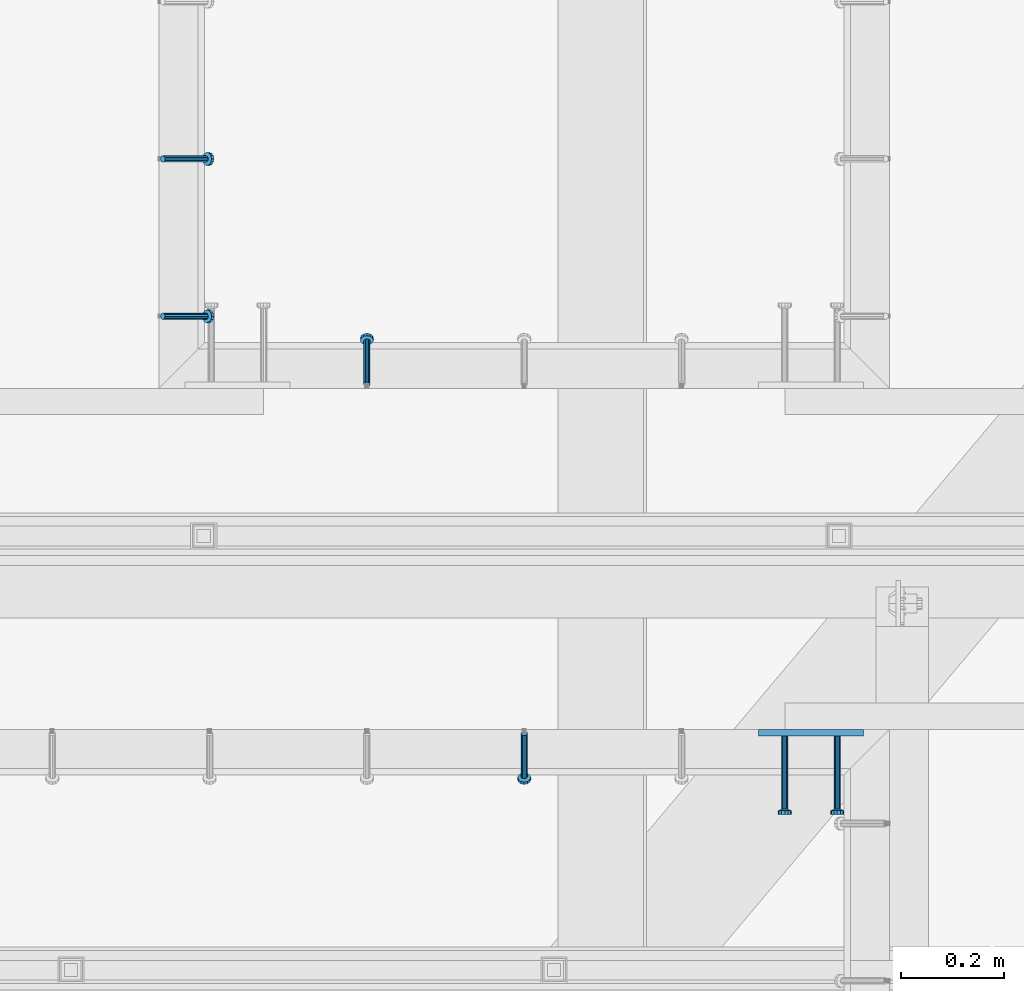
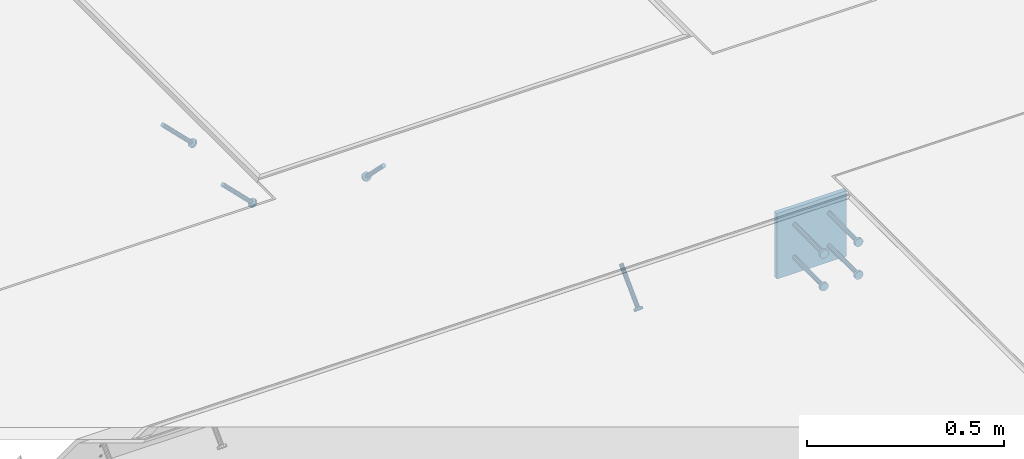
# One storey, part 2120 of 3843: 5 beams, 4 members, 4 elements without a shape of their own.
"""IFC2X3 building model written with IfcOpenShell, lengths in millimetres."""

from ifc_helpers import new_model, si_unit, frame, origin_with_axes, place, context, subcontext, project, spatial, faceted_brep, material, type_object, element, aggregate, save


model = new_model("IFC2X3")

# Units and contexts
model_context = context("Model", 3, precision=1e-05, world=origin_with_axes())
body_context = subcontext(model_context, "Body", "Model", "MODEL_VIEW")
ifc_project = project(units=[si_unit("LENGTHUNIT", "METRE", prefix="MILLI"), si_unit("AREAUNIT", "SQUARE_METRE"), si_unit("VOLUMEUNIT", "CUBIC_METRE"), si_unit("MASSUNIT", "GRAM", prefix="KILO"), si_unit("TIMEUNIT", "SECOND"), si_unit("PLANEANGLEUNIT", "RADIAN"), si_unit("SOLIDANGLEUNIT", "STERADIAN"), si_unit("THERMODYNAMICTEMPERATUREUNIT", "DEGREE_CELSIUS"), si_unit("LUMINOUSINTENSITYUNIT", "LUMEN")], contexts=[model_context])

# Site, building, storey
site_placement = place(None, origin_with_axes())
site = spatial("IfcSite", under=ifc_project, at=site_placement, CompositionType="ELEMENT")
building_placement = place(site_placement, origin_with_axes())
building = spatial("IfcBuilding", under=site, at=building_placement, Name="Undefined", CompositionType="ELEMENT")
storey_placement = place(building_placement, origin_with_axes())
storey = spatial("IfcBuildingStorey", under=building, at=storey_placement, Name="Undefined", CompositionType="ELEMENT", Elevation=0.0)

# Assembly, member
assembly_1_placement = place(storey_placement, origin_with_axes())
assembly_1 = element("IfcElementAssembly", 1, at=assembly_1_placement, inside=storey, Name="EMBED_ANGLE", AssemblyPlace="NOTDEFINED", PredefinedType="RIGID_FRAME")
ifc_material_1 = material(Name="STEEL/A108")
member_type = type_object("IfcMemberType", PredefinedType="NOTDEFINED")
member_1_placement = place(assembly_1_placement, frame((50270.5370209961, 28836.9375, 30446.6625), z_axis=(-1.0, 0.0, 0.0), x_axis=(5.70000238222118e-08, 0.707106781186546, -0.707106781186546)))
member_1 = element("IfcMember", 2, at=member_1_placement, type_object=member_type, material=ifc_material_1, Name="HEADED STUD ANCHOR", context=body_context, shape_type="Brep", body=[
    faceted_brep([(7.27595761418343e-12, -3.18000006675175, 5.5), (0.0, -5.49999999998363, 3.1800000667572), (118.110000000976, -5.49999999999091, 3.1800000667572), (118.110000000983, -3.18000006675175, 5.5), (0.0, -6.3499999046162, 0.0), (118.110000000968, -6.34999990461256, 0.0), (0.0, -5.49999999998363, -3.1800000667572), (118.110000000976, -5.49999999999091, -3.1800000667572), (7.27595761418343e-12, -3.18000006675175, -5.5), (118.110000000983, -3.18000006675175, -5.5), (7.27595761418343e-12, -1.81898940354586e-12, -6.34999990463257), (118.110000000968, -1.81898940354586e-12, -6.34999990463257), (0.0, 3.18000006675175, -5.5), (118.110000000968, 3.18000006674811, -5.5), (7.27595761418343e-12, 5.49999999998363, -3.1800000667572), (118.110000000983, 5.49999999998363, -3.1800000667572), (7.27595761418343e-12, 6.3499999046162, 0.0), (118.110000000976, 6.34999990461256, 0.0), (7.27595761418343e-12, 5.49999999998363, 3.1800000667572), (118.110000000983, 5.49999999998363, 3.1800000667572), (0.0, 3.18000006675175, 5.5), (118.110000000968, 3.18000006674811, 5.5), (7.27595761418343e-12, -1.81898940354586e-12, 6.34999990463257), (118.110000000968, -1.81898940354586e-12, 6.34999990463257), (120.650000000991, -10.9899997710909, 6.34999990463257), (120.650000000998, -6.34000015257152, 10.9899997711182), (120.650000000991, -12.6999998092379, 0.0), (120.650000000991, -10.9899997710909, -6.34999990463257), (120.650000000998, -6.34000015257152, -10.9899997711182), (120.650000000991, -1.81898940354586e-12, -12.6899995803833), (120.650000000991, 6.34000015257152, -10.9899997711182), (120.650000000998, 10.9899997710909, -6.34999990463257), (120.650000000991, 12.6999998092342, 0.0), (120.650000000998, 10.9899997710909, 6.34999990463257), (120.650000000991, 6.34000015257152, 10.9899997711182), (120.650000000991, -1.81898940354586e-12, 12.6899995803833), (127.000000001048, -10.9899997710945, 6.34999990463257), (127.000000001048, -6.34000015257152, 10.9899997711182), (127.000000001048, -12.6999998092342, 0.0), (127.000000001048, -10.9899997710945, -6.34999990463257), (127.000000001048, -6.34000015257152, -10.9899997711182), (127.000000001048, 1.81898940354586e-12, -12.6899995803833), (127.000000001048, 6.34000015256788, -10.9899997711182), (127.000000001048, 10.9899997710909, -6.34999990463257), (127.000000001048, 12.6999998092379, 0.0), (127.000000001048, 10.9899997710909, 6.34999990463257), (127.000000001048, 6.34000015256788, 10.9899997711182), (127.000000001048, 1.81898940354586e-12, 12.6899995803833)], [[[0, 1, 2, 3]], [[1, 4, 5, 2]], [[4, 6, 7, 5]], [[6, 8, 9, 7]], [[8, 10, 11, 9]], [[10, 12, 13, 11]], [[12, 14, 15, 13]], [[14, 16, 17, 15]], [[16, 18, 19, 17]], [[18, 20, 21, 19]], [[20, 22, 23, 21]], [[22, 0, 3, 23]], [[22, 20, 18, 16, 14, 12, 10, 8, 6, 4, 1, 0]], [[3, 2, 24, 25]], [[2, 5, 26, 24]], [[5, 7, 27, 26]], [[7, 9, 28, 27]], [[9, 11, 29, 28]], [[11, 13, 30, 29]], [[13, 15, 31, 30]], [[15, 17, 32, 31]], [[17, 19, 33, 32]], [[19, 21, 34, 33]], [[21, 23, 35, 34]], [[23, 3, 25, 35]], [[25, 24, 36, 37]], [[24, 26, 38, 36]], [[26, 27, 39, 38]], [[27, 28, 40, 39]], [[28, 29, 41, 40]], [[29, 30, 42, 41]], [[30, 31, 43, 42]], [[31, 32, 44, 43]], [[32, 33, 45, 44]], [[33, 34, 46, 45]], [[34, 35, 47, 46]], [[35, 25, 37, 47]], [[38, 39, 40, 41, 42, 43, 44, 45, 46, 47, 37, 36]]]),
])
aggregate(assembly_1, [member_1])

assembly_2_placement = place(storey_placement, origin_with_axes())
assembly_2 = element("IfcElementAssembly", 3, at=assembly_2_placement, inside=storey, Name="EMBED_ANGLE", AssemblyPlace="NOTDEFINED", PredefinedType="RIGID_FRAME")
member_2_placement = place(assembly_2_placement, frame((50575.337, 28160.6625, 30446.6625), z_axis=(-1.0, 0.0, 0.0), x_axis=(0.0, -0.707106781186548, -0.707106781186548)))
member_2 = element("IfcMember", 4, at=member_2_placement, type_object=member_type, material=ifc_material_1, Name="HEADED STUD ANCHOR", context=body_context, shape_type="Brep", body=[
    faceted_brep([(7.27595761418343e-12, -3.18000006675175, 5.5), (0.0, -5.49999999998363, 3.1800000667572), (118.110000000976, -5.49999999999091, 3.1800000667572), (118.110000000983, -3.18000006675175, 5.5), (0.0, -6.3499999046162, 0.0), (118.110000000968, -6.34999990461256, 0.0), (0.0, -5.49999999998363, -3.1800000667572), (118.110000000976, -5.49999999999091, -3.1800000667572), (7.27595761418343e-12, -3.18000006675175, -5.5), (118.110000000983, -3.18000006675175, -5.5), (7.27595761418343e-12, -1.81898940354586e-12, -6.34999990463257), (118.110000000968, -1.81898940354586e-12, -6.34999990463257), (0.0, 3.18000006675175, -5.5), (118.110000000968, 3.18000006674811, -5.5), (7.27595761418343e-12, 5.49999999998363, -3.1800000667572), (118.110000000983, 5.49999999998363, -3.1800000667572), (7.27595761418343e-12, 6.3499999046162, 0.0), (118.110000000976, 6.34999990461256, 0.0), (7.27595761418343e-12, 5.49999999998363, 3.1800000667572), (118.110000000983, 5.49999999998363, 3.1800000667572), (0.0, 3.18000006675175, 5.5), (118.110000000968, 3.18000006674811, 5.5), (7.27595761418343e-12, -1.81898940354586e-12, 6.34999990463257), (118.110000000968, -1.81898940354586e-12, 6.34999990463257), (120.650000000991, -10.9899997710909, 6.34999990463257), (120.650000000998, -6.34000015257152, 10.9899997711182), (120.650000000991, -12.6999998092379, 0.0), (120.650000000991, -10.9899997710909, -6.34999990463257), (120.650000000998, -6.34000015257152, -10.9899997711182), (120.650000000991, -1.81898940354586e-12, -12.6899995803833), (120.650000000991, 6.34000015257152, -10.9899997711182), (120.650000000998, 10.9899997710909, -6.34999990463257), (120.650000000991, 12.6999998092342, 0.0), (120.650000000998, 10.9899997710909, 6.34999990463257), (120.650000000991, 6.34000015257152, 10.9899997711182), (120.650000000991, -1.81898940354586e-12, 12.6899995803833), (127.000000001048, -10.9899997710945, 6.34999990463257), (127.000000001048, -6.34000015257152, 10.9899997711182), (127.000000001048, -12.6999998092342, 0.0), (127.000000001048, -10.9899997710945, -6.34999990463257), (127.000000001048, -6.34000015257152, -10.9899997711182), (127.000000001048, 1.81898940354586e-12, -12.6899995803833), (127.000000001048, 6.34000015256788, -10.9899997711182), (127.000000001048, 10.9899997710909, -6.34999990463257), (127.000000001048, 12.6999998092379, 0.0), (127.000000001048, 10.9899997710909, 6.34999990463257), (127.000000001048, 6.34000015256788, 10.9899997711182), (127.000000001048, 1.81898940354586e-12, 12.6899995803833)], [[[0, 1, 2, 3]], [[1, 4, 5, 2]], [[4, 6, 7, 5]], [[6, 8, 9, 7]], [[8, 10, 11, 9]], [[10, 12, 13, 11]], [[12, 14, 15, 13]], [[14, 16, 17, 15]], [[16, 18, 19, 17]], [[18, 20, 21, 19]], [[20, 22, 23, 21]], [[22, 0, 3, 23]], [[22, 20, 18, 16, 14, 12, 10, 8, 6, 4, 1, 0]], [[3, 2, 24, 25]], [[2, 5, 26, 24]], [[5, 7, 27, 26]], [[7, 9, 28, 27]], [[9, 11, 29, 28]], [[11, 13, 30, 29]], [[13, 15, 31, 30]], [[15, 17, 32, 31]], [[17, 19, 33, 32]], [[19, 21, 34, 33]], [[21, 23, 35, 34]], [[23, 3, 25, 35]], [[25, 24, 36, 37]], [[24, 26, 38, 36]], [[26, 27, 39, 38]], [[27, 28, 40, 39]], [[28, 29, 41, 40]], [[29, 30, 42, 41]], [[30, 31, 43, 42]], [[31, 32, 44, 43]], [[32, 33, 45, 44]], [[33, 34, 46, 45]], [[34, 35, 47, 46]], [[35, 25, 37, 47]], [[38, 39, 40, 41, 42, 43, 44, 45, 46, 47, 37, 36]]]),
])
aggregate(assembly_2, [member_2])

# Assembly, members
assembly_3_placement = place(storey_placement, origin_with_axes())
assembly_3 = element("IfcElementAssembly", 5, at=assembly_3_placement, inside=storey, Name="EMBED_ANGLE", AssemblyPlace="NOTDEFINED", PredefinedType="RIGID_FRAME")
member_3_placement = place(assembly_3_placement, frame((49875.2495576171, 28968.826609375, 30446.6625), z_axis=(0.0, 1.0, 0.0), x_axis=(0.707106781186548, 0.0, -0.707106781186548)))
member_3 = element("IfcMember", 6, at=member_3_placement, type_object=member_type, material=ifc_material_1, Name="HEADED STUD ANCHOR", context=body_context, shape_type="Brep", body=[
    faceted_brep([(7.27595761418343e-12, -3.18000006675175, 5.5), (0.0, -5.49999999998363, 3.1800000667572), (118.110000000976, -5.49999999999091, 3.1800000667572), (118.110000000983, -3.18000006675175, 5.5), (0.0, -6.3499999046162, 0.0), (118.110000000968, -6.34999990461256, 0.0), (0.0, -5.49999999998363, -3.1800000667572), (118.110000000976, -5.49999999999091, -3.1800000667572), (7.27595761418343e-12, -3.18000006675175, -5.5), (118.110000000983, -3.18000006675175, -5.5), (7.27595761418343e-12, -1.81898940354586e-12, -6.34999990463257), (118.110000000968, -1.81898940354586e-12, -6.34999990463257), (0.0, 3.18000006675175, -5.5), (118.110000000968, 3.18000006674811, -5.5), (7.27595761418343e-12, 5.49999999998363, -3.1800000667572), (118.110000000983, 5.49999999998363, -3.1800000667572), (7.27595761418343e-12, 6.3499999046162, 0.0), (118.110000000976, 6.34999990461256, 0.0), (7.27595761418343e-12, 5.49999999998363, 3.1800000667572), (118.110000000983, 5.49999999998363, 3.1800000667572), (0.0, 3.18000006675175, 5.5), (118.110000000968, 3.18000006674811, 5.5), (7.27595761418343e-12, -1.81898940354586e-12, 6.34999990463257), (118.110000000968, -1.81898940354586e-12, 6.34999990463257), (120.650000000991, -10.9899997710909, 6.34999990463257), (120.650000000998, -6.34000015257152, 10.9899997711182), (120.650000000991, -12.6999998092379, 0.0), (120.650000000991, -10.9899997710909, -6.34999990463257), (120.650000000998, -6.34000015257152, -10.9899997711182), (120.650000000991, -1.81898940354586e-12, -12.6899995803833), (120.650000000991, 6.34000015257152, -10.9899997711182), (120.650000000998, 10.9899997710909, -6.34999990463257), (120.650000000991, 12.6999998092342, 0.0), (120.650000000998, 10.9899997710909, 6.34999990463257), (120.650000000991, 6.34000015257152, 10.9899997711182), (120.650000000991, -1.81898940354586e-12, 12.6899995803833), (127.000000001048, -10.9899997710945, 6.34999990463257), (127.000000001048, -6.34000015257152, 10.9899997711182), (127.000000001048, -12.6999998092342, 0.0), (127.000000001048, -10.9899997710945, -6.34999990463257), (127.000000001048, -6.34000015257152, -10.9899997711182), (127.000000001048, 1.81898940354586e-12, -12.6899995803833), (127.000000001048, 6.34000015256788, -10.9899997711182), (127.000000001048, 10.9899997710909, -6.34999990463257), (127.000000001048, 12.6999998092379, 0.0), (127.000000001048, 10.9899997710909, 6.34999990463257), (127.000000001048, 6.34000015256788, 10.9899997711182), (127.000000001048, 1.81898940354586e-12, 12.6899995803833)], [[[0, 1, 2, 3]], [[1, 4, 5, 2]], [[4, 6, 7, 5]], [[6, 8, 9, 7]], [[8, 10, 11, 9]], [[10, 12, 13, 11]], [[12, 14, 15, 13]], [[14, 16, 17, 15]], [[16, 18, 19, 17]], [[18, 20, 21, 19]], [[20, 22, 23, 21]], [[22, 0, 3, 23]], [[22, 20, 18, 16, 14, 12, 10, 8, 6, 4, 1, 0]], [[3, 2, 24, 25]], [[2, 5, 26, 24]], [[5, 7, 27, 26]], [[7, 9, 28, 27]], [[9, 11, 29, 28]], [[11, 13, 30, 29]], [[13, 15, 31, 30]], [[15, 17, 32, 31]], [[17, 19, 33, 32]], [[19, 21, 34, 33]], [[21, 23, 35, 34]], [[23, 3, 25, 35]], [[25, 24, 36, 37]], [[24, 26, 38, 36]], [[26, 27, 39, 38]], [[27, 28, 40, 39]], [[28, 29, 41, 40]], [[29, 30, 42, 41]], [[30, 31, 43, 42]], [[31, 32, 44, 43]], [[32, 33, 45, 44]], [[33, 34, 46, 45]], [[34, 35, 47, 46]], [[35, 25, 37, 47]], [[38, 39, 40, 41, 42, 43, 44, 45, 46, 47, 37, 36]]]),
])
member_4_placement = place(assembly_3_placement, frame((49875.2495576171, 29273.626609375, 30446.6625), z_axis=(0.0, 1.0, 0.0), x_axis=(0.707106781186548, 0.0, -0.707106781186548)))
member_4 = element("IfcMember", 7, at=member_4_placement, type_object=member_type, material=ifc_material_1, Name="HEADED STUD ANCHOR", context=body_context, shape_type="Brep", body=[
    faceted_brep([(7.27595761418343e-12, -3.18000006675175, 5.5), (0.0, -5.49999999998363, 3.1800000667572), (118.110000000976, -5.49999999999091, 3.1800000667572), (118.110000000983, -3.18000006675175, 5.5), (0.0, -6.3499999046162, 0.0), (118.110000000968, -6.34999990461256, 0.0), (0.0, -5.49999999998363, -3.1800000667572), (118.110000000976, -5.49999999999091, -3.1800000667572), (7.27595761418343e-12, -3.18000006675175, -5.5), (118.110000000983, -3.18000006675175, -5.5), (7.27595761418343e-12, -1.81898940354586e-12, -6.34999990463257), (118.110000000968, -1.81898940354586e-12, -6.34999990463257), (0.0, 3.18000006675175, -5.5), (118.110000000968, 3.18000006674811, -5.5), (7.27595761418343e-12, 5.49999999998363, -3.1800000667572), (118.110000000983, 5.49999999998363, -3.1800000667572), (7.27595761418343e-12, 6.3499999046162, 0.0), (118.110000000976, 6.34999990461256, 0.0), (7.27595761418343e-12, 5.49999999998363, 3.1800000667572), (118.110000000983, 5.49999999998363, 3.1800000667572), (0.0, 3.18000006675175, 5.5), (118.110000000968, 3.18000006674811, 5.5), (7.27595761418343e-12, -1.81898940354586e-12, 6.34999990463257), (118.110000000968, -1.81898940354586e-12, 6.34999990463257), (120.650000000991, -10.9899997710909, 6.34999990463257), (120.650000000998, -6.34000015257152, 10.9899997711182), (120.650000000991, -12.6999998092379, 0.0), (120.650000000991, -10.9899997710909, -6.34999990463257), (120.650000000998, -6.34000015257152, -10.9899997711182), (120.650000000991, -1.81898940354586e-12, -12.6899995803833), (120.650000000991, 6.34000015257152, -10.9899997711182), (120.650000000998, 10.9899997710909, -6.34999990463257), (120.650000000991, 12.6999998092342, 0.0), (120.650000000998, 10.9899997710909, 6.34999990463257), (120.650000000991, 6.34000015257152, 10.9899997711182), (120.650000000991, -1.81898940354586e-12, 12.6899995803833), (127.000000001048, -10.9899997710945, 6.34999990463257), (127.000000001048, -6.34000015257152, 10.9899997711182), (127.000000001048, -12.6999998092342, 0.0), (127.000000001048, -10.9899997710945, -6.34999990463257), (127.000000001048, -6.34000015257152, -10.9899997711182), (127.000000001048, 1.81898940354586e-12, -12.6899995803833), (127.000000001048, 6.34000015256788, -10.9899997711182), (127.000000001048, 10.9899997710909, -6.34999990463257), (127.000000001048, 12.6999998092379, 0.0), (127.000000001048, 10.9899997710909, 6.34999990463257), (127.000000001048, 6.34000015256788, 10.9899997711182), (127.000000001048, 1.81898940354586e-12, 12.6899995803833)], [[[0, 1, 2, 3]], [[1, 4, 5, 2]], [[4, 6, 7, 5]], [[6, 8, 9, 7]], [[8, 10, 11, 9]], [[10, 12, 13, 11]], [[12, 14, 15, 13]], [[14, 16, 17, 15]], [[16, 18, 19, 17]], [[18, 20, 21, 19]], [[20, 22, 23, 21]], [[22, 0, 3, 23]], [[22, 20, 18, 16, 14, 12, 10, 8, 6, 4, 1, 0]], [[3, 2, 24, 25]], [[2, 5, 26, 24]], [[5, 7, 27, 26]], [[7, 9, 28, 27]], [[9, 11, 29, 28]], [[11, 13, 30, 29]], [[13, 15, 31, 30]], [[15, 17, 32, 31]], [[17, 19, 33, 32]], [[19, 21, 34, 33]], [[21, 23, 35, 34]], [[23, 3, 25, 35]], [[25, 24, 36, 37]], [[24, 26, 38, 36]], [[26, 27, 39, 38]], [[27, 28, 40, 39]], [[28, 29, 41, 40]], [[29, 30, 42, 41]], [[30, 31, 43, 42]], [[31, 32, 44, 43]], [[32, 33, 45, 44]], [[33, 34, 46, 45]], [[34, 35, 47, 46]], [[35, 25, 37, 47]], [[38, 39, 40, 41, 42, 43, 44, 45, 46, 47, 37, 36]]]),
])
aggregate(assembly_3, [member_3, member_4])

# Assembly, beams
assembly_4_placement = place(storey_placement, origin_with_axes())
assembly_4 = element("IfcElementAssembly", 8, at=assembly_4_placement, inside=storey, Name="EMBED PLATE", AssemblyPlace="NOTDEFINED", PredefinedType="RIGID_FRAME")
ifc_material_2 = material(Name="STEEL/A36")
beam_type_1 = type_object("IfcBeamType", PredefinedType="NOTDEFINED")
beam_1_placement = place(assembly_4_placement, frame((51130.962, 28162.25, 30445.075), z_axis=(-1.0, 0.0, 0.0), x_axis=(0.0, 0.0, -1.0)))
beam_1 = element("IfcBeam", 9, at=beam_1_placement, type_object=beam_type_1, material=ifc_material_2, Name="EMBED PLATE", context=body_context, shape_type="Brep", body=[
    faceted_brep([(1.74622982740402e-10, 6.35000000000582, -101.600000000195), (-1.67347025126219e-10, 6.35000000000582, 101.600000000151), (203.200000000001, 6.35000000000582, 101.599999999999), (203.200000000001, 6.35000000000582, -101.599999999999), (-1.67347025126219e-10, -6.35000000000582, 101.600000000151), (203.200000000001, -6.35000000000582, 101.599999999999), (1.74622982740402e-10, -6.35000000000582, -101.600000000195), (203.200000000001, -6.35000000000582, -101.599999999999)], [[[0, 1, 2, 3]], [[1, 4, 5, 2]], [[4, 6, 7, 5]], [[6, 0, 3, 7]], [[5, 7, 3, 2]], [[6, 4, 1, 0]]]),
])
beam_type_2 = type_object("IfcBeamType", PredefinedType="NOTDEFINED")
beam_2_placement = place(assembly_4_placement, frame((51181.762, 28155.9, 30394.275), z_axis=(1.0, 0.0, 0.0), x_axis=(0.0, -1.0, 0.0)))
beam_2 = element("IfcBeam", 10, at=beam_2_placement, type_object=beam_type_2, material=ifc_material_1, Name="HEADED STUD ANCHOR", context=body_context, shape_type="Brep", body=[
    faceted_brep([(7.27595761418343e-12, -3.18000006675175, 5.5), (0.0, -5.49999999998363, 3.1800000667572), (141.731999999989, -5.5, 3.1800000667572), (141.731999999989, -3.1800000667572, 5.5), (0.0, -6.3499999046162, 0.0), (141.731999999989, -6.34999990463257, 0.0), (0.0, -5.49999999998363, -3.1800000667572), (141.731999999989, -5.5, -3.1800000667572), (7.27595761418343e-12, -3.18000006675175, -5.5), (141.731999999989, -3.1800000667572, -5.5), (7.27595761418343e-12, -1.81898940354586e-12, -6.34999990463257), (141.731999999989, 0.0, -6.34999990463257), (0.0, 3.18000006675175, -5.5), (141.731999999989, 3.1800000667572, -5.5), (7.27595761418343e-12, 5.49999999998363, -3.1800000667572), (141.731999999989, 5.5, -3.1800000667572), (7.27595761418343e-12, 6.3499999046162, 0.0), (141.731999999989, 6.34999990463257, 0.0), (7.27595761418343e-12, 5.49999999998363, 3.1800000667572), (141.731999999989, 5.5, 3.1800000667572), (0.0, 3.18000006675175, 5.5), (141.731999999989, 3.1800000667572, 5.5), (7.27595761418343e-12, -1.81898940354586e-12, 6.34999990463257), (141.731999999989, 0.0, 6.34999990463257), (144.779999999999, -10.9899997711182, 6.34999990463257), (144.779999999999, -6.34000015258789, 10.9899997711182), (144.779999999999, -12.6999998092651, 0.0), (144.779999999999, -10.9899997711182, -6.34999990463257), (144.779999999999, -6.34000015258789, -10.9899997711182), (144.779999999999, 0.0, -12.6899995803833), (144.779999999999, 6.34000015258789, -10.9899997711182), (144.779999999999, 10.9899997711182, -6.34999990463257), (144.779999999999, 12.6999998092651, 0.0), (144.779999999999, 10.9899997711182, 6.34999990463257), (144.779999999999, 6.34000015258789, 10.9899997711182), (144.779999999999, 0.0, 12.6899995803833), (152.399999999994, -10.9899997711182, 6.34999990463257), (152.399999999994, -6.34000015258789, 10.9899997711182), (152.399999999994, -12.6999998092651, 0.0), (152.399999999994, -10.9899997711182, -6.34999990463257), (152.399999999994, -6.34000015258789, -10.9899997711182), (152.399999999994, 0.0, -12.6899995803833), (152.399999999994, 6.34000015258789, -10.9899997711182), (152.399999999994, 10.9899997711182, -6.34999990463257), (152.399999999994, 12.6999998092651, 0.0), (152.399999999994, 10.9899997711182, 6.34999990463257), (152.399999999994, 6.34000015258789, 10.9899997711182), (152.399999999994, 0.0, 12.6899995803833)], [[[0, 1, 2, 3]], [[1, 4, 5, 2]], [[4, 6, 7, 5]], [[6, 8, 9, 7]], [[8, 10, 11, 9]], [[10, 12, 13, 11]], [[12, 14, 15, 13]], [[14, 16, 17, 15]], [[16, 18, 19, 17]], [[18, 20, 21, 19]], [[20, 22, 23, 21]], [[22, 0, 3, 23]], [[22, 20, 18, 16, 14, 12, 10, 8, 6, 4, 1, 0]], [[3, 2, 24, 25]], [[2, 5, 26, 24]], [[5, 7, 27, 26]], [[7, 9, 28, 27]], [[9, 11, 29, 28]], [[11, 13, 30, 29]], [[13, 15, 31, 30]], [[15, 17, 32, 31]], [[17, 19, 33, 32]], [[19, 21, 34, 33]], [[21, 23, 35, 34]], [[23, 3, 25, 35]], [[25, 24, 36, 37]], [[24, 26, 38, 36]], [[26, 27, 39, 38]], [[27, 28, 40, 39]], [[28, 29, 41, 40]], [[29, 30, 42, 41]], [[30, 31, 43, 42]], [[31, 32, 44, 43]], [[32, 33, 45, 44]], [[33, 34, 46, 45]], [[34, 35, 47, 46]], [[35, 25, 37, 47]], [[38, 39, 40, 41, 42, 43, 44, 45, 46, 47, 37, 36]]]),
])
beam_3_placement = place(assembly_4_placement, frame((51181.762, 28155.9, 30292.675), z_axis=(1.0, 0.0, 0.0), x_axis=(0.0, -1.0, 0.0)))
beam_3 = element("IfcBeam", 11, at=beam_3_placement, type_object=beam_type_2, material=ifc_material_1, Name="HEADED STUD ANCHOR", context=body_context, shape_type="Brep", body=[
    faceted_brep([(7.27595761418343e-12, -3.18000006675175, 5.5), (0.0, -5.49999999998363, 3.1800000667572), (141.731999999989, -5.5, 3.1800000667572), (141.731999999989, -3.1800000667572, 5.5), (0.0, -6.3499999046162, 0.0), (141.731999999989, -6.34999990463257, 0.0), (0.0, -5.49999999998363, -3.1800000667572), (141.731999999989, -5.5, -3.1800000667572), (7.27595761418343e-12, -3.18000006675175, -5.5), (141.731999999989, -3.1800000667572, -5.5), (7.27595761418343e-12, -1.81898940354586e-12, -6.34999990463257), (141.731999999989, 0.0, -6.34999990463257), (0.0, 3.18000006675175, -5.5), (141.731999999989, 3.1800000667572, -5.5), (7.27595761418343e-12, 5.49999999998363, -3.1800000667572), (141.731999999989, 5.5, -3.1800000667572), (7.27595761418343e-12, 6.3499999046162, 0.0), (141.731999999989, 6.34999990463257, 0.0), (7.27595761418343e-12, 5.49999999998363, 3.1800000667572), (141.731999999989, 5.5, 3.1800000667572), (0.0, 3.18000006675175, 5.5), (141.731999999989, 3.1800000667572, 5.5), (7.27595761418343e-12, -1.81898940354586e-12, 6.34999990463257), (141.731999999989, 0.0, 6.34999990463257), (144.779999999999, -10.9899997711182, 6.34999990463257), (144.779999999999, -6.34000015258789, 10.9899997711182), (144.779999999999, -12.6999998092651, 0.0), (144.779999999999, -10.9899997711182, -6.34999990463257), (144.779999999999, -6.34000015258789, -10.9899997711182), (144.779999999999, 0.0, -12.6899995803833), (144.779999999999, 6.34000015258789, -10.9899997711182), (144.779999999999, 10.9899997711182, -6.34999990463257), (144.779999999999, 12.6999998092651, 0.0), (144.779999999999, 10.9899997711182, 6.34999990463257), (144.779999999999, 6.34000015258789, 10.9899997711182), (144.779999999999, 0.0, 12.6899995803833), (152.399999999994, -10.9899997711182, 6.34999990463257), (152.399999999994, -6.34000015258789, 10.9899997711182), (152.399999999994, -12.6999998092651, 0.0), (152.399999999994, -10.9899997711182, -6.34999990463257), (152.399999999994, -6.34000015258789, -10.9899997711182), (152.399999999994, 0.0, -12.6899995803833), (152.399999999994, 6.34000015258789, -10.9899997711182), (152.399999999994, 10.9899997711182, -6.34999990463257), (152.399999999994, 12.6999998092651, 0.0), (152.399999999994, 10.9899997711182, 6.34999990463257), (152.399999999994, 6.34000015258789, 10.9899997711182), (152.399999999994, 0.0, 12.6899995803833)], [[[0, 1, 2, 3]], [[1, 4, 5, 2]], [[4, 6, 7, 5]], [[6, 8, 9, 7]], [[8, 10, 11, 9]], [[10, 12, 13, 11]], [[12, 14, 15, 13]], [[14, 16, 17, 15]], [[16, 18, 19, 17]], [[18, 20, 21, 19]], [[20, 22, 23, 21]], [[22, 0, 3, 23]], [[22, 20, 18, 16, 14, 12, 10, 8, 6, 4, 1, 0]], [[3, 2, 24, 25]], [[2, 5, 26, 24]], [[5, 7, 27, 26]], [[7, 9, 28, 27]], [[9, 11, 29, 28]], [[11, 13, 30, 29]], [[13, 15, 31, 30]], [[15, 17, 32, 31]], [[17, 19, 33, 32]], [[19, 21, 34, 33]], [[21, 23, 35, 34]], [[23, 3, 25, 35]], [[25, 24, 36, 37]], [[24, 26, 38, 36]], [[26, 27, 39, 38]], [[27, 28, 40, 39]], [[28, 29, 41, 40]], [[29, 30, 42, 41]], [[30, 31, 43, 42]], [[31, 32, 44, 43]], [[32, 33, 45, 44]], [[33, 34, 46, 45]], [[34, 35, 47, 46]], [[35, 25, 37, 47]], [[38, 39, 40, 41, 42, 43, 44, 45, 46, 47, 37, 36]]]),
])
beam_4_placement = place(assembly_4_placement, frame((51080.162, 28155.9, 30394.275), z_axis=(1.0, 0.0, 0.0), x_axis=(0.0, -1.0, 0.0)))
beam_4 = element("IfcBeam", 12, at=beam_4_placement, type_object=beam_type_2, material=ifc_material_1, Name="HEADED STUD ANCHOR", context=body_context, shape_type="Brep", body=[
    faceted_brep([(7.27595761418343e-12, -3.18000006675175, 5.5), (0.0, -5.49999999998363, 3.1800000667572), (141.731999999989, -5.5, 3.1800000667572), (141.731999999989, -3.1800000667572, 5.5), (0.0, -6.3499999046162, 0.0), (141.731999999989, -6.34999990463257, 0.0), (0.0, -5.49999999998363, -3.1800000667572), (141.731999999989, -5.5, -3.1800000667572), (7.27595761418343e-12, -3.18000006675175, -5.5), (141.731999999989, -3.1800000667572, -5.5), (7.27595761418343e-12, -1.81898940354586e-12, -6.34999990463257), (141.731999999989, 0.0, -6.34999990463257), (0.0, 3.18000006675175, -5.5), (141.731999999989, 3.1800000667572, -5.5), (7.27595761418343e-12, 5.49999999998363, -3.1800000667572), (141.731999999989, 5.5, -3.1800000667572), (7.27595761418343e-12, 6.3499999046162, 0.0), (141.731999999989, 6.34999990463257, 0.0), (7.27595761418343e-12, 5.49999999998363, 3.1800000667572), (141.731999999989, 5.5, 3.1800000667572), (0.0, 3.18000006675175, 5.5), (141.731999999989, 3.1800000667572, 5.5), (7.27595761418343e-12, -1.81898940354586e-12, 6.34999990463257), (141.731999999989, 0.0, 6.34999990463257), (144.779999999999, -10.9899997711182, 6.34999990463257), (144.779999999999, -6.34000015258789, 10.9899997711182), (144.779999999999, -12.6999998092651, 0.0), (144.779999999999, -10.9899997711182, -6.34999990463257), (144.779999999999, -6.34000015258789, -10.9899997711182), (144.779999999999, 0.0, -12.6899995803833), (144.779999999999, 6.34000015258789, -10.9899997711182), (144.779999999999, 10.9899997711182, -6.34999990463257), (144.779999999999, 12.6999998092651, 0.0), (144.779999999999, 10.9899997711182, 6.34999990463257), (144.779999999999, 6.34000015258789, 10.9899997711182), (144.779999999999, 0.0, 12.6899995803833), (152.399999999994, -10.9899997711182, 6.34999990463257), (152.399999999994, -6.34000015258789, 10.9899997711182), (152.399999999994, -12.6999998092651, 0.0), (152.399999999994, -10.9899997711182, -6.34999990463257), (152.399999999994, -6.34000015258789, -10.9899997711182), (152.399999999994, 0.0, -12.6899995803833), (152.399999999994, 6.34000015258789, -10.9899997711182), (152.399999999994, 10.9899997711182, -6.34999990463257), (152.399999999994, 12.6999998092651, 0.0), (152.399999999994, 10.9899997711182, 6.34999990463257), (152.399999999994, 6.34000015258789, 10.9899997711182), (152.399999999994, 0.0, 12.6899995803833)], [[[0, 1, 2, 3]], [[1, 4, 5, 2]], [[4, 6, 7, 5]], [[6, 8, 9, 7]], [[8, 10, 11, 9]], [[10, 12, 13, 11]], [[12, 14, 15, 13]], [[14, 16, 17, 15]], [[16, 18, 19, 17]], [[18, 20, 21, 19]], [[20, 22, 23, 21]], [[22, 0, 3, 23]], [[22, 20, 18, 16, 14, 12, 10, 8, 6, 4, 1, 0]], [[3, 2, 24, 25]], [[2, 5, 26, 24]], [[5, 7, 27, 26]], [[7, 9, 28, 27]], [[9, 11, 29, 28]], [[11, 13, 30, 29]], [[13, 15, 31, 30]], [[15, 17, 32, 31]], [[17, 19, 33, 32]], [[19, 21, 34, 33]], [[21, 23, 35, 34]], [[23, 3, 25, 35]], [[25, 24, 36, 37]], [[24, 26, 38, 36]], [[26, 27, 39, 38]], [[27, 28, 40, 39]], [[28, 29, 41, 40]], [[29, 30, 42, 41]], [[30, 31, 43, 42]], [[31, 32, 44, 43]], [[32, 33, 45, 44]], [[33, 34, 46, 45]], [[34, 35, 47, 46]], [[35, 25, 37, 47]], [[38, 39, 40, 41, 42, 43, 44, 45, 46, 47, 37, 36]]]),
])
beam_5_placement = place(assembly_4_placement, frame((51080.162, 28155.9, 30292.675), z_axis=(1.0, 0.0, 0.0), x_axis=(0.0, -1.0, 0.0)))
beam_5 = element("IfcBeam", 13, at=beam_5_placement, type_object=beam_type_2, material=ifc_material_1, Name="HEADED STUD ANCHOR", context=body_context, shape_type="Brep", body=[
    faceted_brep([(7.27595761418343e-12, -3.18000006675175, 5.5), (0.0, -5.49999999998363, 3.1800000667572), (141.731999999989, -5.5, 3.1800000667572), (141.731999999989, -3.1800000667572, 5.5), (0.0, -6.3499999046162, 0.0), (141.731999999989, -6.34999990463257, 0.0), (0.0, -5.49999999998363, -3.1800000667572), (141.731999999989, -5.5, -3.1800000667572), (7.27595761418343e-12, -3.18000006675175, -5.5), (141.731999999989, -3.1800000667572, -5.5), (7.27595761418343e-12, -1.81898940354586e-12, -6.34999990463257), (141.731999999989, 0.0, -6.34999990463257), (0.0, 3.18000006675175, -5.5), (141.731999999989, 3.1800000667572, -5.5), (7.27595761418343e-12, 5.49999999998363, -3.1800000667572), (141.731999999989, 5.5, -3.1800000667572), (7.27595761418343e-12, 6.3499999046162, 0.0), (141.731999999989, 6.34999990463257, 0.0), (7.27595761418343e-12, 5.49999999998363, 3.1800000667572), (141.731999999989, 5.5, 3.1800000667572), (0.0, 3.18000006675175, 5.5), (141.731999999989, 3.1800000667572, 5.5), (7.27595761418343e-12, -1.81898940354586e-12, 6.34999990463257), (141.731999999989, 0.0, 6.34999990463257), (144.779999999999, -10.9899997711182, 6.34999990463257), (144.779999999999, -6.34000015258789, 10.9899997711182), (144.779999999999, -12.6999998092651, 0.0), (144.779999999999, -10.9899997711182, -6.34999990463257), (144.779999999999, -6.34000015258789, -10.9899997711182), (144.779999999999, 0.0, -12.6899995803833), (144.779999999999, 6.34000015258789, -10.9899997711182), (144.779999999999, 10.9899997711182, -6.34999990463257), (144.779999999999, 12.6999998092651, 0.0), (144.779999999999, 10.9899997711182, 6.34999990463257), (144.779999999999, 6.34000015258789, 10.9899997711182), (144.779999999999, 0.0, 12.6899995803833), (152.399999999994, -10.9899997711182, 6.34999990463257), (152.399999999994, -6.34000015258789, 10.9899997711182), (152.399999999994, -12.6999998092651, 0.0), (152.399999999994, -10.9899997711182, -6.34999990463257), (152.399999999994, -6.34000015258789, -10.9899997711182), (152.399999999994, 0.0, -12.6899995803833), (152.399999999994, 6.34000015258789, -10.9899997711182), (152.399999999994, 10.9899997711182, -6.34999990463257), (152.399999999994, 12.6999998092651, 0.0), (152.399999999994, 10.9899997711182, 6.34999990463257), (152.399999999994, 6.34000015258789, 10.9899997711182), (152.399999999994, 0.0, 12.6899995803833)], [[[0, 1, 2, 3]], [[1, 4, 5, 2]], [[4, 6, 7, 5]], [[6, 8, 9, 7]], [[8, 10, 11, 9]], [[10, 12, 13, 11]], [[12, 14, 15, 13]], [[14, 16, 17, 15]], [[16, 18, 19, 17]], [[18, 20, 21, 19]], [[20, 22, 23, 21]], [[22, 0, 3, 23]], [[22, 20, 18, 16, 14, 12, 10, 8, 6, 4, 1, 0]], [[3, 2, 24, 25]], [[2, 5, 26, 24]], [[5, 7, 27, 26]], [[7, 9, 28, 27]], [[9, 11, 29, 28]], [[11, 13, 30, 29]], [[13, 15, 31, 30]], [[15, 17, 32, 31]], [[17, 19, 33, 32]], [[19, 21, 34, 33]], [[21, 23, 35, 34]], [[23, 3, 25, 35]], [[25, 24, 36, 37]], [[24, 26, 38, 36]], [[26, 27, 39, 38]], [[27, 28, 40, 39]], [[28, 29, 41, 40]], [[29, 30, 42, 41]], [[30, 31, 43, 42]], [[31, 32, 44, 43]], [[32, 33, 45, 44]], [[33, 34, 46, 45]], [[34, 35, 47, 46]], [[35, 25, 37, 47]], [[38, 39, 40, 41, 42, 43, 44, 45, 46, 47, 37, 36]]]),
])
aggregate(assembly_4, [beam_2, beam_3, beam_4, beam_5, beam_1])

save(model, "model.ifc")
